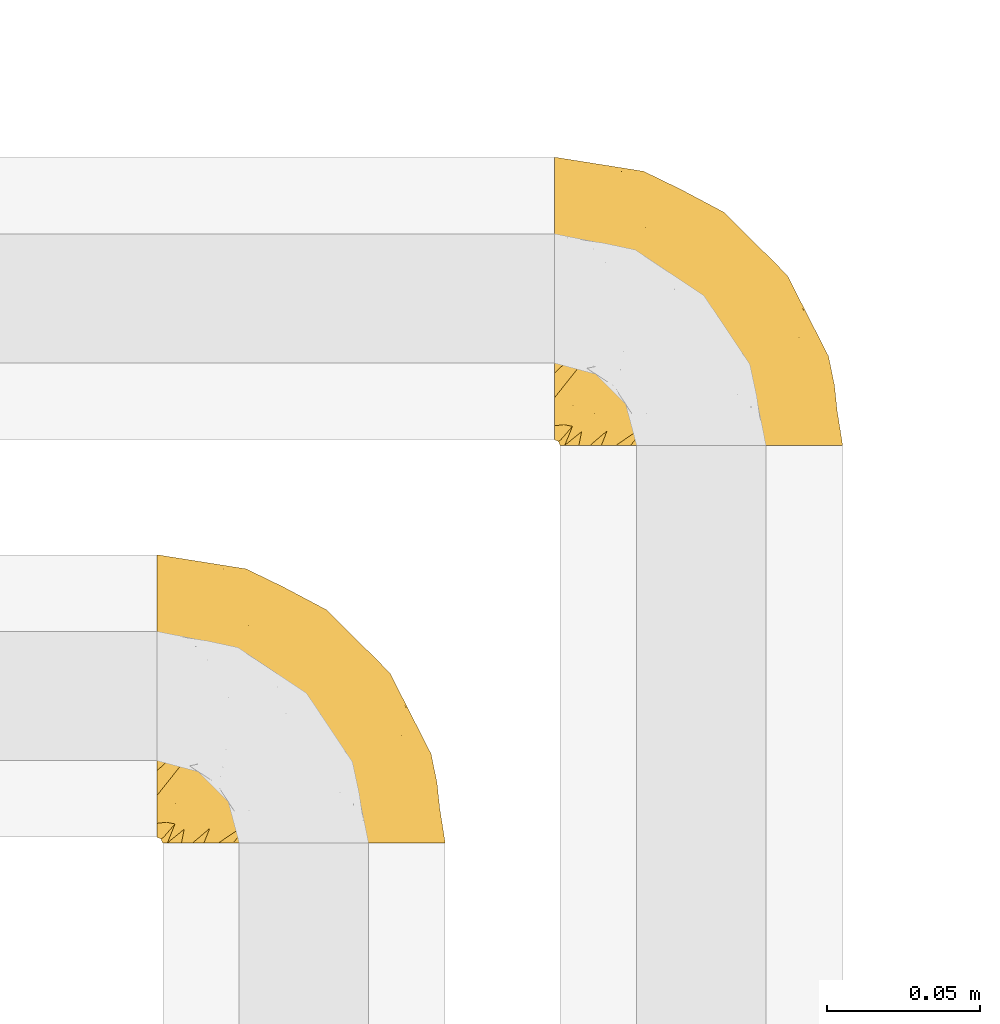
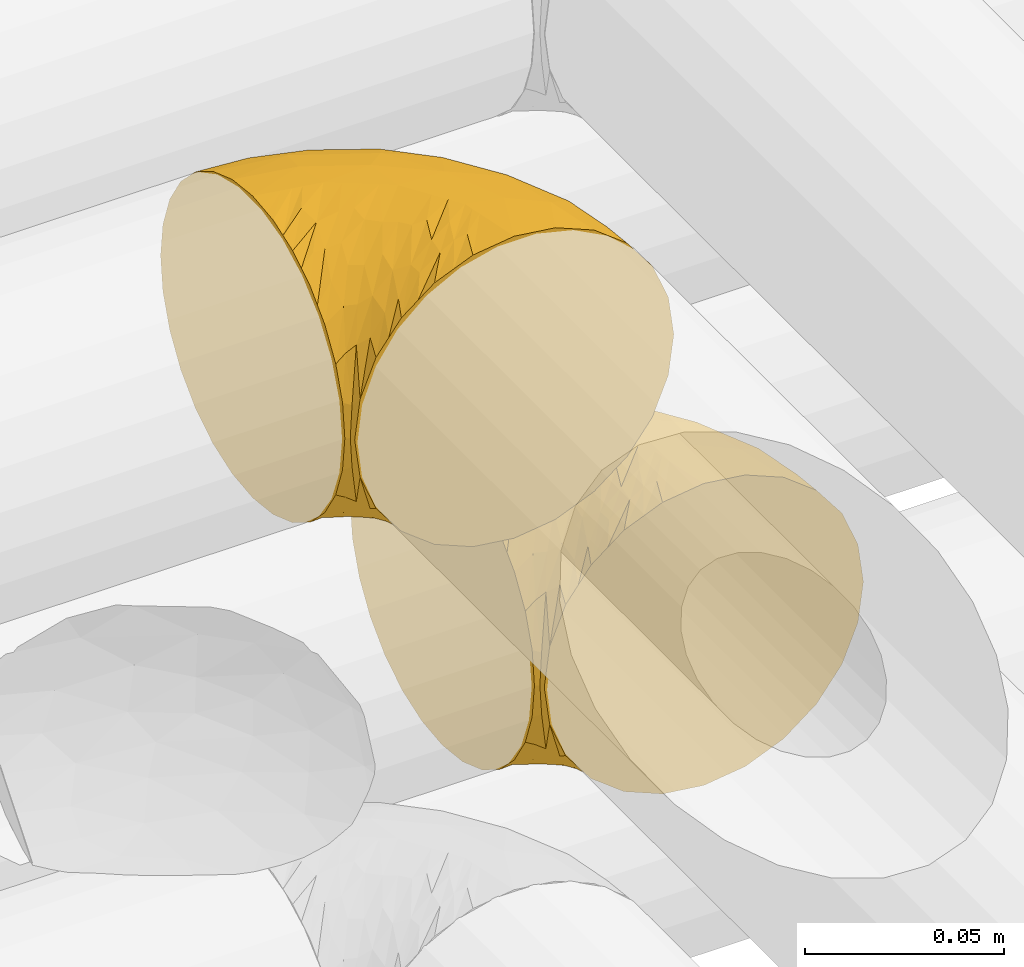
# One storey, part 276 of 827: 2 coverings.
"""IFC2X3 building model written with IfcOpenShell, lengths in millimetres."""

from ifc_helpers import new_model, entity, si_unit, converted_unit, derived_unit, direction, frame, origin, place, context, subcontext, project, spatial, faceted_brep, element, save


model = new_model("IFC2X3")

# Units and contexts
model_context = context("Model", 3, precision=0.01, world=origin(), true_north=direction((6.12303176911189e-17, 1.0)))
body_context = subcontext(model_context, "Body", "Model", "MODEL_VIEW")
ifc_project = project(units=[si_unit("LENGTHUNIT", "METRE", prefix="MILLI"), si_unit("AREAUNIT", "SQUARE_METRE"), si_unit("VOLUMEUNIT", "CUBIC_METRE"), converted_unit("PLANEANGLEUNIT", "DEGREE", entity("IfcRatioMeasure", 0.0174532925199433), si_unit("PLANEANGLEUNIT", "RADIAN"), dimensions=[0, 0, 0, 0, 0, 0, 0]), si_unit("MASSUNIT", "GRAM", prefix="KILO"), derived_unit("MASSDENSITYUNIT", [(si_unit("MASSUNIT", "GRAM", prefix="KILO"), 1), (si_unit("LENGTHUNIT", "METRE"), -3)]), derived_unit("MOMENTOFINERTIAUNIT", [(si_unit("LENGTHUNIT", "METRE"), 4)]), si_unit("TIMEUNIT", "SECOND"), si_unit("FREQUENCYUNIT", "HERTZ"), si_unit("THERMODYNAMICTEMPERATUREUNIT", "DEGREE_CELSIUS"), derived_unit("THERMALTRANSMITTANCEUNIT", [(si_unit("MASSUNIT", "GRAM", prefix="KILO"), 1), (si_unit("THERMODYNAMICTEMPERATUREUNIT", "KELVIN"), -1), (si_unit("TIMEUNIT", "SECOND"), -3)]), derived_unit("VOLUMETRICFLOWRATEUNIT", [(si_unit("LENGTHUNIT", "METRE"), 3), (si_unit("TIMEUNIT", "SECOND"), -1)]), derived_unit("MASSFLOWRATEUNIT", [(si_unit("MASSUNIT", "GRAM", prefix="KILO"), 1), (si_unit("TIMEUNIT", "SECOND"), -1)]), derived_unit("ROTATIONALFREQUENCYUNIT", [(si_unit("TIMEUNIT", "SECOND"), -1)]), si_unit("ELECTRICCURRENTUNIT", "AMPERE"), si_unit("ELECTRICVOLTAGEUNIT", "VOLT"), si_unit("POWERUNIT", "WATT"), si_unit("FORCEUNIT", "NEWTON", prefix="KILO"), si_unit("ILLUMINANCEUNIT", "LUX"), si_unit("LUMINOUSFLUXUNIT", "LUMEN"), si_unit("LUMINOUSINTENSITYUNIT", "CANDELA"), derived_unit("USERDEFINED", [(si_unit("MASSUNIT", "GRAM", prefix="KILO"), -1), (si_unit("LENGTHUNIT", "METRE"), -2), (si_unit("TIMEUNIT", "SECOND"), 3), (si_unit("LUMINOUSFLUXUNIT", "LUMEN"), 1)]), derived_unit("LINEARVELOCITYUNIT", [(si_unit("LENGTHUNIT", "METRE"), 1), (si_unit("TIMEUNIT", "SECOND"), -1)]), si_unit("PRESSUREUNIT", "PASCAL"), derived_unit("USERDEFINED", [(si_unit("LENGTHUNIT", "METRE"), -2), (si_unit("MASSUNIT", "GRAM", prefix="KILO"), 1), (si_unit("TIMEUNIT", "SECOND"), -2)]), derived_unit("LINEARFORCEUNIT", [(si_unit("MASSUNIT", "GRAM", prefix="KILO"), 1), (si_unit("LENGTHUNIT", "METRE"), 1), (si_unit("TIMEUNIT", "SECOND"), -2), (si_unit("LENGTHUNIT", "METRE"), -1)]), derived_unit("PLANARFORCEUNIT", [(si_unit("MASSUNIT", "GRAM", prefix="KILO"), 1), (si_unit("LENGTHUNIT", "METRE"), 1), (si_unit("TIMEUNIT", "SECOND"), -2), (si_unit("LENGTHUNIT", "METRE"), -2)])], contexts=[model_context])

# Site, building, storey
site_placement = place(None, origin())
site = spatial("IfcSite", under=ifc_project, at=site_placement, CompositionType="ELEMENT")
building_placement = place(site_placement, origin())
building = spatial("IfcBuilding", under=site, at=building_placement, CompositionType="ELEMENT")
storey_placement = place(building_placement, frame((0.0, 0.0, 28200.0)))
storey = spatial("IfcBuildingStorey", under=building, at=storey_placement, Name="08", CompositionType="ELEMENT", Elevation=28200.0)

# Coverings
covering_1_placement = place(storey_placement, frame((35680.44, 14440.41, 3152.2)))
element("IfcCovering", 1, at=covering_1_placement, inside=storey, Name=":ADSK_", ObjectType=":ADSK_", PredefinedType="INSULATION", context=body_context, shape_type="Brep", body=[
    faceted_brep([(1.6, 78.41, 83.91), (1.6, 85.72, 76.59), (1.6, 91.22, 67.83), (1.6, 94.64, 58.07), (1.6, 95.8, 47.8), (1.6, 94.64, 37.51), (1.6, 91.22, 27.74), (1.6, 85.71, 18.98), (1.6, 78.39, 11.67), (1.6, 69.63, 6.17), (1.6, 59.87, 2.75), (1.6, 49.6, 1.6), (1.6, 45.45, 2.06), (1.6, 42.38, 2.41), (1.6, 39.31, 2.75), (1.6, 34.43, 4.46), (1.6, 29.54, 6.17), (1.6, 25.16, 8.93), (1.6, 20.78, 11.68), (1.6, 17.13, 15.34), (1.6, 13.47, 19.0), (1.6, 7.97, 27.76), (1.6, 6.26, 32.64), (1.6, 4.55, 37.52), (1.6, 3.4, 47.8), (1.6, 4.55, 58.08), (1.6, 6.26, 62.96), (1.6, 7.97, 67.85), (1.6, 13.48, 76.61), (1.6, 17.14, 80.26), (1.6, 20.8, 83.92), (1.6, 25.18, 86.67), (1.6, 29.56, 89.42), (1.6, 34.44, 91.13), (1.6, 39.32, 92.84), (1.6, 42.39, 93.18), (1.6, 45.45, 93.53), (1.6, 49.6, 94.0), (1.6, 59.88, 92.84), (1.6, 69.65, 89.42), (3.4, 1.6, 47.8), (4.97, 1.6, 35.84), (9.58, 1.6, 24.7), (13.26, 1.6, 19.91), (16.93, 1.6, 15.13), (21.71, 1.6, 11.46), (26.5, 1.6, 7.78), (32.07, 1.6, 5.48), (37.64, 1.6, 3.17), (41.25, 1.6, 2.69), (43.34, 1.6, 2.42), (45.42, 1.6, 2.14), (49.6, 1.6, 1.6), (61.55, 1.6, 3.17), (72.7, 1.6, 7.78), (82.26, 1.6, 15.13), (89.61, 1.6, 24.7), (94.22, 1.6, 35.84), (95.8, 1.6, 47.8), (94.22, 1.6, 59.75), (89.61, 1.6, 70.9), (82.26, 1.6, 80.46), (72.7, 1.6, 87.81), (61.55, 1.6, 92.42), (49.6, 1.6, 94.0), (45.42, 1.6, 93.45), (41.25, 1.6, 92.9), (37.64, 1.6, 92.42), (32.07, 1.6, 90.11), (26.5, 1.6, 87.81), (21.71, 1.6, 84.13), (16.93, 1.6, 80.46), (13.26, 1.6, 75.68), (9.58, 1.6, 70.9), (4.97, 1.6, 59.75), (81.55, 36.81, 71.98), (90.4, 23.28, 63.6), (83.0, 45.8, 59.72), (91.18, 30.7, 47.8), (93.13, 21.2, 55.16), (94.0, 12.96, 47.8), (66.19, 66.19, 63.76), (70.92, 54.51, 72.22), (85.95, 17.98, 74.18), (49.74, 36.69, 92.52), (35.54, 35.54, 94.0), (38.14, 31.64, 94.0), (40.74, 27.75, 94.0), (43.34, 23.86, 94.0), (45.94, 19.96, 94.0), (77.59, 22.8, 82.14), (71.17, 42.67, 80.34), (65.81, 33.21, 87.52), (59.03, 59.45, 79.59), (45.85, 71.5, 78.25), (45.79, 62.66, 85.01), (41.42, 54.5, 90.25), (34.51, 47.57, 93.2), (56.04, 48.81, 87.23), (15.15, 74.98, 85.55), (56.51, 18.7, 93.0), (68.39, 15.75, 89.31), (23.33, 91.17, 61.31), (42.86, 85.28, 56.86), (39.42, 82.58, 68.34), (53.58, 75.78, 65.71), (59.17, 74.98, 56.99), (59.06, 67.27, 72.15), (22.63, 87.38, 70.34), (20.55, 82.04, 78.36), (12.96, 94.0, 47.8), (56.96, 77.8, 47.8), (67.38, 67.38, 47.8), (18.72, 56.2, 93.06), (5.33, 48.85, 94.0), (9.07, 48.11, 94.0), (11.79, 47.57, 94.0), (14.51, 47.03, 94.0), (17.24, 46.48, 94.0), (19.96, 45.94, 94.0), (21.03, 65.78, 89.88), (46.48, 17.24, 94.0), (47.03, 14.51, 94.0), (47.57, 11.79, 94.0), (48.11, 9.07, 94.0), (48.48, 7.2, 94.0), (48.85, 5.33, 94.0), (30.7, 91.18, 47.8), (23.86, 43.34, 94.0), (27.75, 40.74, 94.0), (31.64, 38.14, 94.0), (31.26, 72.73, 83.7), (77.8, 56.96, 47.8), (72.75, 62.23, 55.9), (43.83, 84.49, 47.8), (84.49, 43.83, 47.8), (14.58, 12.05, 81.75), (16.17, 18.95, 86.43), (10.82, 13.02, 79.8), (4.64, 8.34, 69.84), (7.71, 14.63, 79.5), (25.13, 11.09, 88.08), (32.66, 13.66, 91.6), (34.94, 20.08, 92.93), (36.76, 9.61, 92.43), (40.48, 9.48, 93.24), (39.25, 16.1, 93.36), (3.69, 3.42, 57.25), (13.99, 26.63, 89.41), (21.85, 33.72, 92.89), (17.93, 34.77, 92.66), (15.11, 6.75, 79.58), (21.14, 13.31, 86.51), (7.21, 19.94, 83.91), (9.47, 27.05, 88.76), (32.27, 8.67, 90.94), (25.68, 26.11, 91.94), (22.18, 29.3, 91.98), (18.79, 6.32, 82.79), (10.12, 39.92, 93.16), (10.45, 6.04, 73.94), (11.29, 34.4, 91.89), (2.87, 2.87, 47.8), (31.16, 20.92, 92.22), (12.7, 21.11, 86.29), (6.31, 27.43, 88.56), (25.62, 7.54, 87.72), (21.18, 18.45, 88.33), (28.81, 23.88, 92.18), (7.45, 7.77, 71.78), (21.17, 18.43, 7.27), (16.17, 18.93, 9.17), (25.69, 26.08, 3.66), (48.85, 5.33, 1.6), (47.03, 14.51, 1.6), (47.57, 11.79, 1.6), (48.11, 9.07, 1.6), (3.69, 3.42, 38.35), (7.44, 7.76, 23.84), (14.51, 47.03, 1.6), (11.79, 47.57, 1.6), (5.33, 48.85, 1.6), (9.07, 48.11, 1.6), (7.71, 14.62, 16.1), (9.47, 27.03, 6.84), (34.94, 20.08, 2.66), (31.16, 20.92, 3.37), (40.74, 27.75, 1.6), (38.14, 31.64, 1.6), (18.79, 6.33, 12.8), (36.76, 9.61, 3.16), (40.48, 9.48, 2.35), (4.63, 8.33, 25.77), (21.14, 13.3, 9.09), (15.11, 6.74, 16.02), (14.58, 12.04, 13.85), (43.34, 23.86, 1.6), (45.94, 19.96, 1.6), (39.25, 16.1, 2.23), (7.21, 19.93, 11.69), (12.69, 21.1, 9.31), (10.14, 39.92, 2.43), (21.81, 33.68, 2.71), (22.19, 29.28, 3.61), (14.0, 26.62, 6.18), (6.66, 27.87, 6.77), (17.92, 34.75, 2.93), (10.45, 6.04, 21.66), (31.64, 38.14, 1.6), (10.64, 12.79, 16.09), (11.31, 34.41, 3.7), (19.96, 45.94, 1.6), (23.86, 43.34, 1.6), (27.75, 40.74, 1.6), (32.66, 13.66, 3.99), (46.48, 17.24, 1.6), (32.27, 8.67, 4.65), (25.13, 11.09, 7.51), (35.54, 35.54, 1.6), (28.77, 23.83, 3.43), (23.36, 6.03, 9.46), (17.24, 46.48, 1.6), (47.58, 34.52, 2.4), (93.13, 21.2, 40.43), (77.44, 23.82, 13.57), (66.78, 41.32, 11.3), (71.68, 47.62, 18.65), (74.96, 52.66, 27.26), (81.55, 36.81, 23.61), (36.7, 49.75, 3.07), (56.9, 19.07, 2.69), (83.0, 45.8, 35.87), (90.4, 23.28, 31.99), (67.83, 21.35, 6.71), (85.95, 17.98, 21.41), (39.41, 82.57, 27.24), (23.33, 91.17, 34.26), (42.87, 85.27, 38.73), (53.92, 73.89, 26.97), (66.19, 66.19, 31.83), (64.12, 62.43, 23.4), (33.13, 63.53, 6.91), (23.1, 58.45, 3.4), (16.98, 67.16, 5.84), (55.72, 76.72, 35.73), (72.75, 62.22, 39.69), (23.77, 81.54, 17.6), (18.41, 74.8, 10.38), (43.7, 75.83, 20.6), (54.53, 41.45, 5.36), (17.73, 88.2, 24.84), (38.98, 71.6, 13.87), (50.28, 56.23, 9.06), (59.02, 59.44, 15.99)], [[[0, 1, 2, 3, 4, 5, 6, 7, 8, 9, 10, 11, 12, 13, 14, 15, 16, 17, 18, 19, 20, 21, 22, 23, 24, 25, 26, 27, 28, 29, 30, 31, 32, 33, 34, 35, 36, 37, 38, 39]], [[40, 41, 42, 43, 44, 45, 46, 47, 48, 49, 50, 51, 52, 53, 54, 55, 56, 57, 58, 59, 60, 61, 62, 63, 64, 65, 66, 67, 68, 69, 70, 71, 72, 73, 74]], [[75, 76, 77]], [[78, 79, 80]], [[77, 81, 82]], [[76, 75, 83]], [[84, 85, 86, 87, 88, 89]], [[90, 91, 92]], [[76, 60, 59]], [[93, 94, 95]], [[90, 62, 61]], [[83, 61, 60]], [[96, 97, 84]], [[98, 93, 95]], [[0, 39, 99]], [[100, 84, 89]], [[62, 101, 63]], [[2, 102, 3]], [[92, 84, 100]], [[103, 102, 104]], [[103, 105, 106]], [[93, 107, 94]], [[1, 108, 2]], [[92, 101, 90]], [[108, 1, 109]], [[102, 110, 3]], [[93, 82, 107]], [[102, 108, 104]], [[111, 106, 112]], [[109, 0, 99]], [[113, 37, 114, 115, 116, 117, 118, 119]], [[120, 38, 113]], [[100, 89, 121, 122, 123, 124, 125, 126, 64]], [[127, 102, 103]], [[97, 119, 128, 129, 130, 85]], [[99, 120, 131]], [[132, 133, 77]], [[59, 80, 79]], [[1, 0, 109]], [[98, 84, 92]], [[94, 109, 131]], [[120, 39, 38]], [[93, 91, 82]], [[104, 94, 105]], [[97, 113, 119]], [[95, 120, 96]], [[83, 90, 61]], [[91, 93, 98]], [[64, 63, 100]], [[100, 63, 101]], [[77, 76, 79]], [[133, 106, 81]], [[84, 97, 85]], [[113, 96, 120]], [[113, 97, 96]], [[37, 113, 38]], [[110, 102, 127]], [[110, 4, 3]], [[103, 111, 134, 127]], [[90, 75, 91]], [[82, 81, 107]], [[91, 75, 82]], [[77, 82, 75]], [[76, 83, 60]], [[90, 83, 75]], [[105, 107, 81]], [[94, 131, 95]], [[105, 94, 107]], [[109, 94, 104]], [[120, 95, 131]], [[98, 95, 96]], [[84, 98, 96]], [[98, 92, 91]], [[106, 105, 81]], [[103, 104, 105]], [[133, 132, 112]], [[103, 106, 111]], [[77, 78, 135, 132]], [[106, 133, 112]], [[77, 133, 81]], [[120, 99, 39]], [[109, 99, 131]], [[59, 58, 80]], [[59, 79, 76]], [[90, 101, 62]], [[100, 101, 92]], [[2, 108, 102]], [[109, 104, 108]], [[78, 77, 79]], [[136, 137, 138]], [[27, 139, 140]], [[141, 142, 143]], [[144, 145, 121]], [[146, 89, 88]], [[147, 139, 25]], [[148, 149, 150]], [[136, 151, 152]], [[147, 40, 74]], [[24, 147, 25]], [[153, 148, 154]], [[33, 116, 34]], [[73, 72, 151]], [[114, 37, 36, 35, 34, 116, 115]], [[146, 155, 144]], [[156, 85, 130]], [[157, 149, 148]], [[151, 158, 152]], [[117, 33, 159]], [[29, 153, 154]], [[160, 74, 73]], [[161, 128, 119]], [[66, 65, 64, 126, 125, 124, 123, 122, 67]], [[162, 147, 24]], [[27, 140, 28]], [[149, 129, 150]], [[139, 27, 26, 25]], [[68, 144, 69]], [[129, 128, 150]], [[163, 87, 86]], [[130, 129, 149]], [[122, 145, 67]], [[153, 164, 148]], [[161, 119, 159]], [[165, 30, 154]], [[150, 154, 148]], [[128, 161, 150]], [[30, 165, 31]], [[145, 144, 68]], [[89, 146, 144]], [[87, 163, 143]], [[166, 155, 142]], [[88, 87, 143]], [[161, 154, 150]], [[154, 30, 29]], [[29, 28, 153]], [[28, 140, 153]], [[164, 153, 140]], [[140, 137, 164]], [[157, 148, 164]], [[156, 130, 157]], [[164, 137, 157]], [[157, 137, 156]], [[167, 137, 136]], [[168, 85, 156]], [[152, 168, 167]], [[167, 168, 156]], [[163, 152, 141]], [[71, 158, 72]], [[152, 167, 136]], [[88, 142, 146]], [[144, 155, 69]], [[146, 142, 155]], [[70, 166, 71]], [[142, 141, 166]], [[70, 69, 155]], [[141, 158, 71]], [[160, 73, 151]], [[138, 137, 140]], [[160, 136, 169]], [[136, 160, 151]], [[74, 160, 169]], [[152, 158, 141]], [[151, 72, 158]], [[168, 152, 163]], [[137, 167, 156]], [[163, 86, 168]], [[85, 168, 86]], [[116, 33, 117]], [[130, 149, 157]], [[67, 145, 68]], [[121, 89, 144]], [[145, 122, 121]], [[40, 147, 162]], [[169, 147, 74]], [[159, 33, 32]], [[161, 159, 32]], [[159, 119, 118, 117]], [[139, 147, 169]], [[139, 169, 138]], [[161, 32, 31]], [[141, 143, 163]], [[88, 143, 142]], [[71, 166, 141]], [[155, 166, 70]], [[139, 138, 140]], [[169, 136, 138]], [[154, 161, 165]], [[161, 31, 165]], [[170, 171, 172]], [[173, 52, 51, 50, 49, 48, 174, 175, 176]], [[177, 178, 41]], [[179, 15, 180]], [[12, 11, 181, 182, 180, 14, 13]], [[183, 21, 20]], [[19, 18, 184]], [[185, 186, 187]], [[186, 188, 187]], [[43, 189, 44]], [[190, 191, 47]], [[23, 22, 21, 192]], [[193, 194, 195]], [[40, 162, 177]], [[196, 197, 198]], [[24, 23, 177]], [[199, 200, 183]], [[201, 15, 179]], [[47, 46, 190]], [[202, 203, 204]], [[203, 172, 171]], [[205, 206, 184]], [[207, 41, 178]], [[16, 15, 201]], [[14, 180, 15]], [[204, 203, 200]], [[208, 203, 202]], [[162, 24, 177]], [[48, 47, 191]], [[198, 197, 190]], [[199, 184, 204]], [[171, 195, 209]], [[210, 211, 212]], [[206, 212, 213]], [[205, 17, 210]], [[184, 206, 204]], [[210, 212, 206]], [[185, 196, 214]], [[190, 215, 191]], [[216, 45, 214]], [[186, 217, 193]], [[190, 216, 198]], [[199, 20, 19]], [[196, 185, 187]], [[199, 183, 20]], [[184, 199, 19]], [[199, 204, 200]], [[206, 202, 204]], [[171, 183, 200]], [[203, 208, 172]], [[172, 208, 218]], [[171, 200, 203]], [[218, 188, 219]], [[195, 170, 193]], [[217, 186, 185]], [[193, 219, 186]], [[193, 170, 219]], [[207, 194, 42]], [[217, 220, 189]], [[216, 190, 46]], [[214, 196, 198]], [[44, 220, 45]], [[214, 198, 216]], [[216, 46, 45]], [[214, 45, 220]], [[42, 194, 43]], [[189, 193, 217]], [[207, 195, 194]], [[209, 195, 178]], [[41, 207, 42]], [[195, 207, 178]], [[43, 194, 189]], [[193, 189, 194]], [[171, 170, 195]], [[170, 172, 219]], [[218, 219, 172]], [[188, 186, 219]], [[206, 213, 202]], [[208, 202, 213]], [[201, 210, 16]], [[215, 190, 197]], [[215, 174, 191]], [[174, 48, 191]], [[201, 179, 221, 211]], [[210, 201, 211]], [[23, 192, 177]], [[40, 177, 41]], [[178, 177, 192]], [[21, 183, 192]], [[209, 192, 183]], [[205, 18, 17]], [[17, 16, 210]], [[217, 185, 214]], [[189, 220, 44]], [[214, 220, 217]], [[192, 209, 178]], [[171, 209, 183]], [[206, 205, 210]], [[18, 205, 184]], [[222, 197, 196, 187, 188, 218]], [[57, 223, 80]], [[224, 225, 226]], [[226, 227, 228]], [[229, 218, 208, 213, 212, 211]], [[230, 52, 173, 176, 175, 174, 215, 197]], [[231, 232, 228]], [[231, 78, 223]], [[223, 57, 232]], [[224, 233, 225]], [[233, 54, 53]], [[234, 232, 56]], [[56, 55, 234]], [[234, 224, 228]], [[235, 236, 237]], [[224, 55, 54]], [[238, 239, 240]], [[52, 230, 53]], [[241, 242, 243]], [[239, 244, 245]], [[11, 10, 242]], [[236, 6, 5]], [[7, 246, 8]], [[8, 247, 9]], [[238, 248, 235]], [[222, 229, 249]], [[242, 211, 221, 179, 180, 182, 181, 11]], [[233, 53, 230]], [[111, 112, 244]], [[250, 6, 236]], [[247, 251, 241]], [[6, 250, 7]], [[127, 236, 110]], [[249, 229, 252]], [[247, 8, 246]], [[235, 246, 250]], [[236, 5, 110]], [[235, 244, 238]], [[237, 236, 127]], [[243, 9, 247]], [[252, 229, 241]], [[56, 232, 57]], [[222, 230, 197]], [[225, 249, 252]], [[249, 233, 230]], [[54, 233, 224]], [[231, 228, 227]], [[245, 132, 231]], [[249, 225, 233]], [[226, 225, 253]], [[235, 250, 236]], [[246, 7, 250]], [[251, 247, 246]], [[243, 247, 241]], [[248, 246, 235]], [[252, 251, 253]], [[229, 222, 218]], [[230, 222, 249]], [[5, 4, 110]], [[237, 127, 134, 111]], [[238, 244, 239]], [[224, 234, 55]], [[232, 234, 228]], [[242, 241, 229]], [[10, 9, 243]], [[211, 242, 229]], [[10, 243, 242]], [[80, 223, 78]], [[80, 58, 57]], [[231, 223, 232]], [[227, 240, 239]], [[224, 226, 228]], [[240, 226, 253]], [[227, 239, 245]], [[226, 240, 227]], [[251, 248, 253]], [[240, 253, 248]], [[244, 235, 237]], [[237, 111, 244]], [[132, 245, 112]], [[112, 245, 244]], [[135, 78, 231, 132]], [[227, 245, 231]], [[248, 238, 240]], [[246, 248, 251]], [[251, 252, 241]], [[225, 252, 253]]]),
])
covering_2_placement = place(storey_placement, frame((35550.5, 14310.41, 3352.2)))
element("IfcCovering", 2, at=covering_2_placement, inside=storey, Name=":ADSK_", ObjectType=":ADSK_", PredefinedType="INSULATION", context=body_context, shape_type="Brep", body=[
    faceted_brep([(1.6, 78.41, 83.91), (1.6, 85.72, 76.59), (1.6, 91.22, 67.83), (1.6, 94.64, 58.07), (1.6, 95.8, 47.8), (1.6, 94.64, 37.51), (1.6, 91.22, 27.74), (1.6, 85.71, 18.98), (1.6, 78.39, 11.67), (1.6, 69.63, 6.17), (1.6, 59.87, 2.75), (1.6, 49.6, 1.6), (1.6, 45.45, 2.06), (1.6, 42.38, 2.41), (1.6, 39.31, 2.75), (1.6, 34.43, 4.46), (1.6, 29.54, 6.17), (1.6, 25.16, 8.93), (1.6, 20.78, 11.68), (1.6, 17.13, 15.34), (1.6, 13.47, 19.0), (1.6, 7.97, 27.76), (1.6, 6.26, 32.64), (1.6, 4.55, 37.52), (1.6, 3.4, 47.8), (1.6, 4.55, 58.08), (1.6, 6.26, 62.96), (1.6, 7.97, 67.85), (1.6, 13.48, 76.61), (1.6, 17.14, 80.26), (1.6, 20.8, 83.92), (1.6, 25.18, 86.67), (1.6, 29.56, 89.42), (1.6, 34.44, 91.13), (1.6, 39.32, 92.84), (1.6, 42.39, 93.18), (1.6, 45.45, 93.53), (1.6, 49.6, 94.0), (1.6, 59.88, 92.84), (1.6, 69.65, 89.42), (3.4, 1.6, 47.8), (4.97, 1.6, 35.84), (9.58, 1.6, 24.7), (13.26, 1.6, 19.91), (16.93, 1.6, 15.13), (21.71, 1.6, 11.46), (26.5, 1.6, 7.78), (32.07, 1.6, 5.48), (37.64, 1.6, 3.17), (41.25, 1.6, 2.69), (43.34, 1.6, 2.42), (45.42, 1.6, 2.14), (49.6, 1.6, 1.6), (61.55, 1.6, 3.17), (72.7, 1.6, 7.78), (82.26, 1.6, 15.13), (89.61, 1.6, 24.7), (94.22, 1.6, 35.84), (95.8, 1.6, 47.8), (94.22, 1.6, 59.75), (89.61, 1.6, 70.9), (82.26, 1.6, 80.46), (72.7, 1.6, 87.81), (61.55, 1.6, 92.42), (49.6, 1.6, 94.0), (45.42, 1.6, 93.45), (41.25, 1.6, 92.9), (37.64, 1.6, 92.42), (32.07, 1.6, 90.11), (26.5, 1.6, 87.81), (21.71, 1.6, 84.13), (16.93, 1.6, 80.46), (13.26, 1.6, 75.68), (9.58, 1.6, 70.9), (4.97, 1.6, 59.75), (81.55, 36.81, 71.98), (90.4, 23.28, 63.6), (83.0, 45.8, 59.72), (91.18, 30.7, 47.8), (93.13, 21.2, 55.16), (94.0, 12.96, 47.8), (66.19, 66.19, 63.76), (70.92, 54.51, 72.22), (85.95, 17.98, 74.18), (49.74, 36.69, 92.52), (35.54, 35.54, 94.0), (38.14, 31.64, 94.0), (40.74, 27.75, 94.0), (43.34, 23.86, 94.0), (45.94, 19.96, 94.0), (77.59, 22.8, 82.14), (71.17, 42.67, 80.34), (65.81, 33.21, 87.52), (59.03, 59.45, 79.59), (45.85, 71.5, 78.25), (45.79, 62.66, 85.01), (41.42, 54.5, 90.25), (34.51, 47.57, 93.2), (56.04, 48.81, 87.23), (15.15, 74.98, 85.55), (56.51, 18.7, 93.0), (68.39, 15.75, 89.31), (23.33, 91.17, 61.31), (42.86, 85.28, 56.86), (39.42, 82.58, 68.34), (53.58, 75.78, 65.71), (59.17, 74.98, 56.99), (59.06, 67.27, 72.15), (22.63, 87.38, 70.34), (20.55, 82.04, 78.36), (12.96, 94.0, 47.8), (56.96, 77.8, 47.8), (67.38, 67.38, 47.8), (18.72, 56.2, 93.06), (5.33, 48.85, 94.0), (9.07, 48.11, 94.0), (11.79, 47.57, 94.0), (14.51, 47.03, 94.0), (17.24, 46.48, 94.0), (19.96, 45.94, 94.0), (21.03, 65.78, 89.88), (46.48, 17.24, 94.0), (47.03, 14.51, 94.0), (47.57, 11.79, 94.0), (48.11, 9.07, 94.0), (48.48, 7.2, 94.0), (48.85, 5.33, 94.0), (30.7, 91.18, 47.8), (23.86, 43.34, 94.0), (27.75, 40.74, 94.0), (31.64, 38.14, 94.0), (31.26, 72.73, 83.7), (77.8, 56.96, 47.8), (72.75, 62.23, 55.9), (43.83, 84.49, 47.8), (84.49, 43.83, 47.8), (14.58, 12.05, 81.75), (16.17, 18.95, 86.43), (10.82, 13.02, 79.8), (4.64, 8.34, 69.84), (7.71, 14.63, 79.5), (25.13, 11.09, 88.08), (32.66, 13.66, 91.6), (34.94, 20.08, 92.93), (36.76, 9.61, 92.43), (40.48, 9.48, 93.24), (39.25, 16.1, 93.36), (3.69, 3.42, 57.25), (13.99, 26.63, 89.41), (21.85, 33.72, 92.89), (17.93, 34.77, 92.66), (15.11, 6.75, 79.58), (21.14, 13.31, 86.51), (7.21, 19.94, 83.91), (9.47, 27.05, 88.76), (32.27, 8.67, 90.94), (25.68, 26.11, 91.94), (22.18, 29.3, 91.98), (18.79, 6.32, 82.79), (10.12, 39.92, 93.16), (10.45, 6.04, 73.94), (11.29, 34.4, 91.89), (2.87, 2.87, 47.8), (31.16, 20.92, 92.22), (12.7, 21.11, 86.29), (6.31, 27.43, 88.56), (25.62, 7.54, 87.72), (21.18, 18.45, 88.33), (28.81, 23.88, 92.18), (7.45, 7.77, 71.78), (21.14, 13.3, 9.09), (25.13, 11.09, 7.51), (18.79, 6.33, 12.8), (48.85, 5.33, 1.6), (47.03, 14.51, 1.6), (47.57, 11.79, 1.6), (48.11, 9.07, 1.6), (3.69, 3.42, 38.35), (7.44, 7.76, 23.84), (14.51, 47.03, 1.6), (11.79, 47.57, 1.6), (5.33, 48.85, 1.6), (9.07, 48.11, 1.6), (7.71, 14.62, 16.1), (9.47, 27.03, 6.84), (34.94, 20.08, 2.66), (31.16, 20.92, 3.37), (40.74, 27.75, 1.6), (38.14, 31.64, 1.6), (36.76, 9.61, 3.16), (40.48, 9.48, 2.35), (4.63, 8.33, 25.77), (15.11, 6.74, 16.02), (14.58, 12.04, 13.85), (43.34, 23.86, 1.6), (45.94, 19.96, 1.6), (39.25, 16.1, 2.23), (7.21, 19.93, 11.69), (12.69, 21.1, 9.31), (10.14, 39.92, 2.43), (21.81, 33.68, 2.71), (22.19, 29.28, 3.61), (14.0, 26.62, 6.18), (25.69, 26.08, 3.66), (16.17, 18.93, 9.17), (6.66, 27.87, 6.77), (17.92, 34.75, 2.93), (10.45, 6.04, 21.66), (31.64, 38.14, 1.6), (10.64, 12.79, 16.09), (11.31, 34.41, 3.7), (19.96, 45.94, 1.6), (23.86, 43.34, 1.6), (27.75, 40.74, 1.6), (32.66, 13.66, 3.99), (46.48, 17.24, 1.6), (32.27, 8.67, 4.65), (35.54, 35.54, 1.6), (28.77, 23.83, 3.43), (21.17, 18.43, 7.27), (23.36, 6.03, 9.46), (17.24, 46.48, 1.6), (47.58, 34.52, 2.4), (93.13, 21.2, 40.43), (77.44, 23.82, 13.57), (66.78, 41.32, 11.3), (71.68, 47.62, 18.65), (74.96, 52.66, 27.26), (81.55, 36.81, 23.61), (36.7, 49.75, 3.07), (56.9, 19.07, 2.69), (83.0, 45.8, 35.87), (90.4, 23.28, 31.99), (67.83, 21.35, 6.71), (85.95, 17.98, 21.41), (39.41, 82.57, 27.24), (23.33, 91.17, 34.26), (42.87, 85.27, 38.73), (53.92, 73.89, 26.97), (66.19, 66.19, 31.83), (64.12, 62.43, 23.4), (33.13, 63.53, 6.91), (23.1, 58.45, 3.4), (16.98, 67.16, 5.84), (55.72, 76.72, 35.73), (72.75, 62.22, 39.69), (23.77, 81.54, 17.6), (18.41, 74.8, 10.38), (43.7, 75.83, 20.6), (54.53, 41.45, 5.36), (17.73, 88.2, 24.84), (38.98, 71.6, 13.87), (50.28, 56.23, 9.06), (59.02, 59.44, 15.99)], [[[0, 1, 2, 3, 4, 5, 6, 7, 8, 9, 10, 11, 12, 13, 14, 15, 16, 17, 18, 19, 20, 21, 22, 23, 24, 25, 26, 27, 28, 29, 30, 31, 32, 33, 34, 35, 36, 37, 38, 39]], [[40, 41, 42, 43, 44, 45, 46, 47, 48, 49, 50, 51, 52, 53, 54, 55, 56, 57, 58, 59, 60, 61, 62, 63, 64, 65, 66, 67, 68, 69, 70, 71, 72, 73, 74]], [[75, 76, 77]], [[78, 79, 80]], [[77, 81, 82]], [[76, 75, 83]], [[84, 85, 86, 87, 88, 89]], [[90, 91, 92]], [[76, 60, 59]], [[93, 94, 95]], [[90, 62, 61]], [[83, 61, 60]], [[96, 97, 84]], [[98, 93, 95]], [[0, 39, 99]], [[100, 84, 89]], [[62, 101, 63]], [[2, 102, 3]], [[92, 84, 100]], [[103, 102, 104]], [[103, 105, 106]], [[93, 107, 94]], [[1, 108, 2]], [[92, 101, 90]], [[108, 1, 109]], [[102, 110, 3]], [[93, 82, 107]], [[102, 108, 104]], [[111, 106, 112]], [[109, 0, 99]], [[113, 37, 114, 115, 116, 117, 118, 119]], [[120, 38, 113]], [[100, 89, 121, 122, 123, 124, 125, 126, 64]], [[127, 102, 103]], [[97, 119, 128, 129, 130, 85]], [[99, 120, 131]], [[132, 133, 77]], [[59, 80, 79]], [[1, 0, 109]], [[98, 84, 92]], [[94, 109, 131]], [[120, 39, 38]], [[93, 91, 82]], [[104, 94, 105]], [[97, 113, 119]], [[95, 120, 96]], [[83, 90, 61]], [[91, 93, 98]], [[64, 63, 100]], [[100, 63, 101]], [[77, 76, 79]], [[133, 106, 81]], [[84, 97, 85]], [[113, 96, 120]], [[113, 97, 96]], [[37, 113, 38]], [[110, 102, 127]], [[110, 4, 3]], [[103, 111, 134, 127]], [[90, 75, 91]], [[82, 81, 107]], [[91, 75, 82]], [[77, 82, 75]], [[76, 83, 60]], [[90, 83, 75]], [[105, 107, 81]], [[94, 131, 95]], [[105, 94, 107]], [[109, 94, 104]], [[120, 95, 131]], [[98, 95, 96]], [[84, 98, 96]], [[98, 92, 91]], [[106, 105, 81]], [[103, 104, 105]], [[112, 106, 133]], [[103, 106, 111]], [[112, 133, 132]], [[81, 77, 133]], [[77, 78, 135, 132]], [[120, 99, 39]], [[109, 99, 131]], [[59, 58, 80]], [[59, 79, 76]], [[90, 101, 62]], [[100, 101, 92]], [[2, 108, 102]], [[109, 104, 108]], [[78, 77, 79]], [[136, 137, 138]], [[27, 139, 140]], [[141, 142, 143]], [[144, 145, 121]], [[146, 89, 88]], [[147, 139, 25]], [[148, 149, 150]], [[136, 151, 152]], [[147, 40, 74]], [[24, 147, 25]], [[153, 148, 154]], [[33, 116, 34]], [[73, 72, 151]], [[114, 37, 36, 35, 34, 116, 115]], [[146, 155, 144]], [[156, 85, 130]], [[157, 149, 148]], [[151, 158, 152]], [[117, 33, 159]], [[29, 153, 154]], [[160, 74, 73]], [[161, 128, 119]], [[66, 65, 64, 126, 125, 124, 123, 122, 67]], [[162, 147, 24]], [[27, 140, 28]], [[149, 129, 150]], [[139, 27, 26, 25]], [[68, 144, 69]], [[129, 128, 150]], [[163, 87, 86]], [[130, 129, 149]], [[122, 145, 67]], [[153, 164, 148]], [[161, 119, 159]], [[165, 30, 154]], [[150, 154, 148]], [[128, 161, 150]], [[30, 165, 31]], [[145, 144, 68]], [[89, 146, 144]], [[87, 163, 143]], [[166, 155, 142]], [[88, 87, 143]], [[161, 154, 150]], [[154, 30, 29]], [[29, 28, 153]], [[28, 140, 153]], [[164, 153, 140]], [[140, 137, 164]], [[157, 148, 164]], [[156, 130, 157]], [[164, 137, 157]], [[157, 137, 156]], [[167, 137, 136]], [[168, 85, 156]], [[152, 168, 167]], [[167, 168, 156]], [[163, 152, 141]], [[71, 158, 72]], [[152, 167, 136]], [[88, 142, 146]], [[144, 155, 69]], [[146, 142, 155]], [[70, 166, 71]], [[142, 141, 166]], [[70, 69, 155]], [[141, 158, 71]], [[160, 73, 151]], [[138, 137, 140]], [[160, 136, 169]], [[136, 160, 151]], [[74, 160, 169]], [[152, 158, 141]], [[151, 72, 158]], [[168, 152, 163]], [[137, 167, 156]], [[163, 86, 168]], [[85, 168, 86]], [[116, 33, 117]], [[130, 149, 157]], [[67, 145, 68]], [[121, 89, 144]], [[145, 122, 121]], [[40, 147, 162]], [[169, 147, 74]], [[159, 33, 32]], [[161, 159, 32]], [[159, 119, 118, 117]], [[139, 147, 169]], [[139, 169, 138]], [[161, 32, 31]], [[141, 143, 163]], [[88, 143, 142]], [[71, 166, 141]], [[155, 166, 70]], [[139, 138, 140]], [[169, 136, 138]], [[154, 161, 165]], [[161, 31, 165]], [[170, 171, 172]], [[173, 52, 51, 50, 49, 48, 174, 175, 176]], [[177, 178, 41]], [[179, 15, 180]], [[12, 11, 181, 182, 180, 14, 13]], [[183, 21, 20]], [[19, 18, 184]], [[185, 186, 187]], [[186, 188, 187]], [[43, 172, 44]], [[189, 190, 47]], [[23, 22, 21, 191]], [[170, 192, 193]], [[40, 162, 177]], [[194, 195, 196]], [[24, 23, 177]], [[197, 198, 183]], [[199, 15, 179]], [[47, 46, 189]], [[200, 201, 202]], [[201, 203, 204]], [[205, 206, 184]], [[207, 41, 178]], [[16, 15, 199]], [[14, 180, 15]], [[202, 201, 198]], [[208, 201, 200]], [[162, 24, 177]], [[48, 47, 190]], [[196, 195, 189]], [[197, 184, 202]], [[204, 193, 209]], [[210, 211, 212]], [[206, 212, 213]], [[205, 17, 210]], [[184, 206, 202]], [[210, 212, 206]], [[185, 194, 214]], [[189, 215, 190]], [[216, 45, 214]], [[186, 171, 170]], [[189, 216, 196]], [[197, 20, 19]], [[194, 185, 187]], [[197, 183, 20]], [[184, 197, 19]], [[197, 202, 198]], [[206, 200, 202]], [[204, 183, 198]], [[201, 208, 203]], [[203, 208, 217]], [[204, 198, 201]], [[217, 188, 218]], [[193, 219, 170]], [[171, 186, 185]], [[170, 218, 186]], [[170, 219, 218]], [[42, 207, 192]], [[171, 220, 172]], [[216, 189, 46]], [[214, 194, 196]], [[44, 220, 45]], [[214, 196, 216]], [[216, 46, 45]], [[214, 45, 220]], [[192, 43, 42]], [[204, 203, 219]], [[207, 193, 192]], [[209, 193, 178]], [[41, 207, 42]], [[193, 207, 178]], [[43, 192, 172]], [[170, 172, 192]], [[204, 219, 193]], [[219, 203, 218]], [[217, 218, 203]], [[188, 186, 218]], [[206, 213, 200]], [[208, 200, 213]], [[199, 210, 16]], [[215, 189, 195]], [[215, 174, 190]], [[174, 48, 190]], [[199, 179, 221, 211]], [[210, 199, 211]], [[23, 191, 177]], [[40, 177, 41]], [[183, 209, 191]], [[183, 191, 21]], [[191, 178, 177]], [[205, 18, 17]], [[17, 16, 210]], [[171, 185, 214]], [[172, 220, 44]], [[214, 220, 171]], [[191, 209, 178]], [[204, 209, 183]], [[206, 205, 210]], [[18, 205, 184]], [[222, 195, 194, 187, 188, 217]], [[57, 223, 80]], [[224, 225, 226]], [[226, 227, 228]], [[229, 217, 208, 213, 212, 211]], [[230, 52, 173, 176, 175, 174, 215, 195]], [[231, 232, 228]], [[231, 78, 223]], [[223, 57, 232]], [[224, 233, 225]], [[233, 54, 53]], [[234, 232, 56]], [[56, 55, 234]], [[234, 224, 228]], [[235, 236, 237]], [[224, 55, 54]], [[238, 239, 240]], [[52, 230, 53]], [[241, 242, 243]], [[239, 244, 245]], [[11, 10, 242]], [[236, 6, 5]], [[7, 246, 8]], [[8, 247, 9]], [[238, 248, 235]], [[222, 229, 249]], [[242, 211, 221, 179, 180, 182, 181, 11]], [[233, 53, 230]], [[111, 112, 244]], [[250, 6, 236]], [[247, 251, 241]], [[6, 250, 7]], [[127, 236, 110]], [[249, 229, 252]], [[247, 8, 246]], [[235, 246, 250]], [[236, 5, 110]], [[235, 244, 238]], [[237, 236, 127]], [[243, 9, 247]], [[252, 229, 241]], [[56, 232, 57]], [[222, 230, 195]], [[225, 249, 252]], [[249, 233, 230]], [[54, 233, 224]], [[231, 228, 227]], [[245, 132, 231]], [[249, 225, 233]], [[226, 225, 253]], [[235, 250, 236]], [[246, 7, 250]], [[251, 247, 246]], [[243, 247, 241]], [[248, 246, 235]], [[252, 251, 253]], [[229, 222, 217]], [[230, 222, 249]], [[5, 4, 110]], [[237, 127, 134, 111]], [[238, 244, 239]], [[224, 234, 55]], [[232, 234, 228]], [[242, 241, 229]], [[10, 9, 243]], [[211, 242, 229]], [[10, 243, 242]], [[80, 223, 78]], [[80, 58, 57]], [[231, 223, 232]], [[227, 240, 239]], [[224, 226, 228]], [[240, 226, 253]], [[227, 239, 245]], [[226, 240, 227]], [[251, 248, 253]], [[240, 253, 248]], [[244, 235, 237]], [[237, 111, 244]], [[132, 245, 112]], [[112, 245, 244]], [[135, 78, 231, 132]], [[227, 245, 231]], [[248, 238, 240]], [[246, 248, 251]], [[251, 252, 241]], [[225, 252, 253]]]),
])

save(model, "model.ifc")
